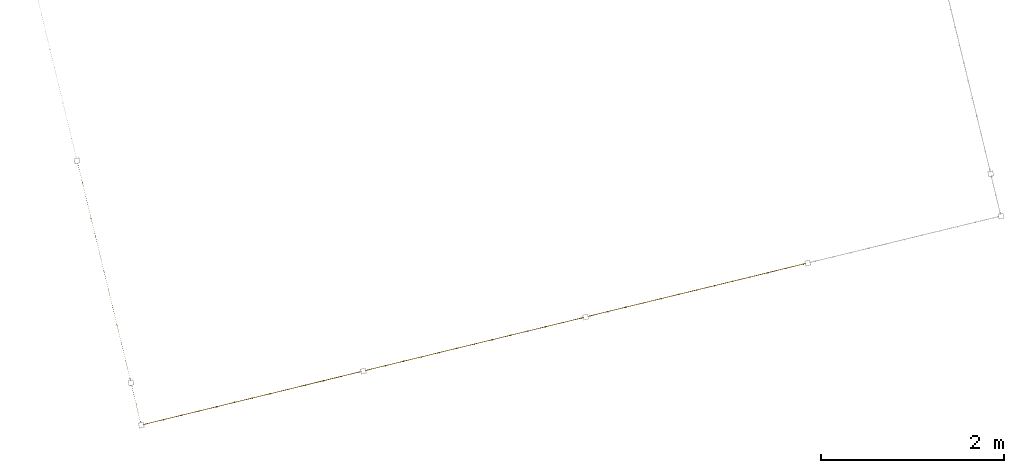
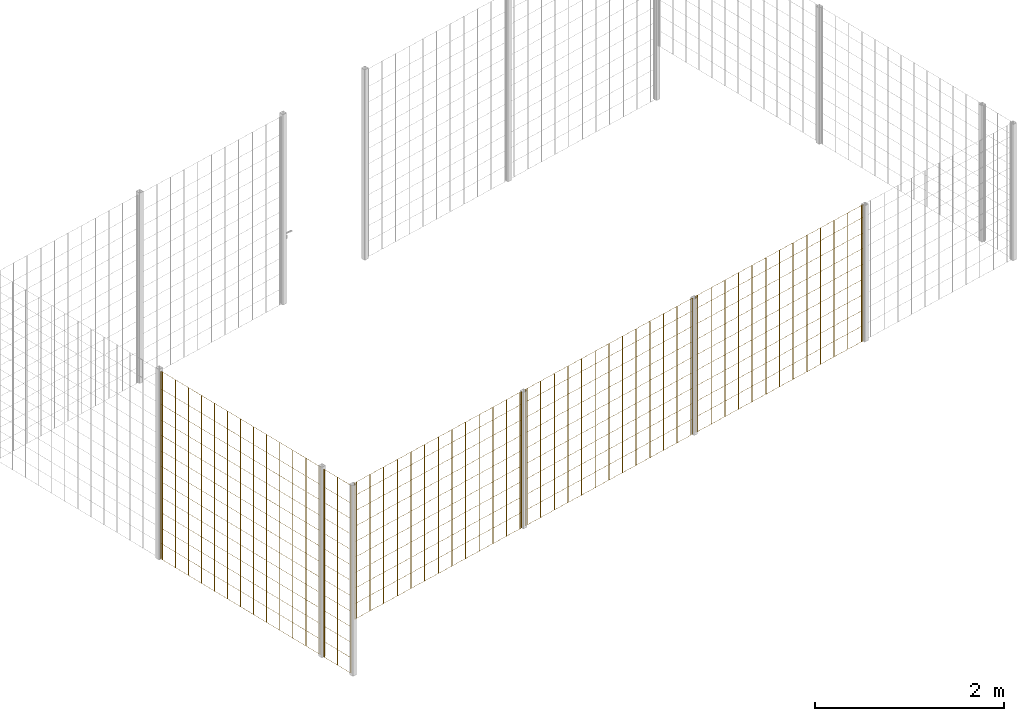
# One storey, part 7 of 10: 5 railings.
"""IFC2X3 building model written with IfcOpenShell, lengths in millimetres."""

import ifcopenshell
import ifcopenshell.guid

model = None  # the IFC model being written
_history = None  # IfcOwnerHistory: only IFC2X3 demands one
_inside = {}  # id of a spatial element -> (the spatial element, [elements in it])
_under = {}  # id of a project, library or spatial element -> (it, [spatial elements below it])
_declared = {}  # id of a project -> (the project, [libraries it declares])
_typed = {}  # id of a type object -> (the type object, [elements of that type])
_made_of = {}  # id of a material, layer set ... -> (it, [elements and type objects made of it])


def new_model(schema):
    """Start an empty IFC model of exactly this schema.

    Asked for "IFC4X3", IfcOpenShell would pick the latest addendum, in which some entities
    have other attributes; the version numbers below select the first issue.
    IFC2X3 requires an IfcOwnerHistory on every rooted entity: one is made here for all.
    """
    global model, _history
    if schema == "IFC4X3":
        model = ifcopenshell.file(schema_version=(4, 3, 0, 0))
    else:
        model = ifcopenshell.file(schema=schema)
    _inside.clear()
    _under.clear()
    _declared.clear()
    _typed.clear()
    _made_of.clear()
    _history = None
    if model.schema == "IFC2X3":
        org = make("IfcOrganization", Name="unknown")
        user = make(
            "IfcPersonAndOrganization",
            ThePerson=make("IfcPerson", FamilyName="unknown"),
            TheOrganization=org,
        )
        app = make(
            "IfcApplication",
            ApplicationDeveloper=org,
            Version="unknown",
            ApplicationFullName="unknown",
            ApplicationIdentifier="unknown",
        )
        _history = make(
            "IfcOwnerHistory",
            OwningUser=user,
            OwningApplication=app,
            ChangeAction="ADDED",
            CreationDate=0,
        )
    return model


def make(cls, **values):
    """One entity of the class cls with the attributes given. An attribute that is None is left unset."""
    return model.create_entity(
        cls, **{name: value for name, value in values.items() if value is not None}
    )


def entity(cls, *values):
    """Any entity or typed value of the class cls, its attributes in the order of the schema. None: left unset."""
    e = model.create_entity(cls)
    for i, value in enumerate(values):
        if value is not None:
            e[i] = value
    return e


def rooted(cls, **values):
    """An entity with a GlobalId (a new one), such as an element, a storey or a relation."""
    return make(cls, GlobalId=ifcopenshell.guid.new(), OwnerHistory=_history, **values)


def si_unit(unit_type, name, prefix=None):
    """IfcSIUnit, for example si_unit("LENGTHUNIT", "METRE", prefix="MILLI")."""
    return make("IfcSIUnit", UnitType=unit_type, Prefix=prefix, Name=name)


def converted_unit(unit_type, name, factor, base, dimensions=None, offset=None):
    """IfcConversionBasedUnit, such as the inch: factor (a typed value) times the base unit."""
    return make(
        "IfcConversionBasedUnit"
        if offset is None
        else "IfcConversionBasedUnitWithOffset",
        ConversionOffset=offset,
        Dimensions=None
        if dimensions is None
        else entity("IfcDimensionalExponents", *dimensions),
        UnitType=unit_type,
        Name=name,
        ConversionFactor=make(
            "IfcMeasureWithUnit", ValueComponent=factor, UnitComponent=base
        ),
    )


def derived_unit(unit_type, elements):
    """IfcDerivedUnit: a product of units, each with its exponent."""
    return make(
        "IfcDerivedUnit",
        Elements=[
            make("IfcDerivedUnitElement", Unit=unit, Exponent=power)
            for unit, power in elements
        ],
        UnitType=unit_type,
    )


def assignment(units):
    """IfcUnitAssignment: the units of a project."""
    return None if units is None else make("IfcUnitAssignment", Units=units)


def point(xyz):
    """IfcCartesianPoint."""
    return None if xyz is None else make("IfcCartesianPoint", Coordinates=xyz)


def direction(xyz):
    """IfcDirection."""
    return None if xyz is None else make("IfcDirection", DirectionRatios=xyz)


def frame(location, z_axis=None, x_axis=None):
    """IfcAxis2Placement3D, a coordinate frame: its origin and axes. An axis left out is left unset."""
    return make(
        "IfcAxis2Placement3D",
        Location=point(location),
        Axis=direction(z_axis),
        RefDirection=direction(x_axis),
    )


def frame_2d(location, x_axis=None):
    """IfcAxis2Placement2D, a coordinate frame in the plane: its origin and x axis."""
    return make(
        "IfcAxis2Placement2D", Location=point(location), RefDirection=direction(x_axis)
    )


def origin():
    """The frame at (0, 0, 0) with its axes left unset."""
    return frame((0.0, 0.0, 0.0))


def origin_2d_with_axis():
    """The frame at (0, 0) in the plane with the x axis (1, 0) written out."""
    return frame_2d((0.0, 0.0), x_axis=(1.0, 0.0))


def place(relative_to, where):
    """IfcLocalPlacement: puts the frame where relative to a parent placement (None: the world)."""
    return make(
        "IfcLocalPlacement", PlacementRelTo=relative_to, RelativePlacement=where
    )


def context(
    kind, dimensions, precision=None, world=None, true_north=None, identifier=None
):
    """IfcGeometricRepresentationContext, for example the 3D "Model" context."""
    return make(
        "IfcGeometricRepresentationContext",
        ContextIdentifier=identifier,
        ContextType=kind,
        CoordinateSpaceDimension=dimensions,
        Precision=precision,
        WorldCoordinateSystem=world,
        TrueNorth=true_north,
    )


def subcontext(parent, identifier, kind, view, scale=None):
    """IfcGeometricRepresentationSubContext, for example "Body" below "Model"."""
    return make(
        "IfcGeometricRepresentationSubContext",
        ContextIdentifier=identifier,
        ContextType=kind,
        ParentContext=parent,
        TargetScale=scale,
        TargetView=view,
    )


def project(units=None, contexts=None):
    """IfcProject with its units and contexts."""
    return rooted(
        "IfcProject",
        Name="project",
        RepresentationContexts=contexts,
        UnitsInContext=assignment(units),
    )


def spatial(cls, under=None, at=None, **own):
    """A site, building, storey or space (cls), placed at a placement, below another one or the project."""
    s = rooted(cls, ObjectPlacement=at, **own)
    if under is not None:
        _under.setdefault(under.id(), (under, []))[1].append(s)
    return s


def profile(cls, at=None, kind="AREA", **sizes):
    """A parametric profile (cls). Its sizes go by their IFC names, for example OverallWidth=200.0."""
    return make(cls, ProfileType=kind, Position=at, **sizes)


def rectangle(**sizes):
    """IfcRectangleProfileDef."""
    return profile("IfcRectangleProfileDef", **sizes)


def circle(**sizes):
    """IfcCircleProfileDef."""
    return profile("IfcCircleProfileDef", **sizes)


def extrude(swept, where, along, depth):
    """IfcExtrudedAreaSolid: the profile swept, set in the frame where, extruded along a direction by depth."""
    return make(
        "IfcExtrudedAreaSolid",
        SweptArea=swept,
        Position=where,
        ExtrudedDirection=direction(along),
        Depth=depth,
    )


def shape(context_of_items, identifier, shape_type, items):
    """IfcShapeRepresentation: the items that make up one representation, for example the "Body"."""
    return make(
        "IfcShapeRepresentation",
        ContextOfItems=context_of_items,
        RepresentationIdentifier=identifier,
        RepresentationType=shape_type,
        Items=items,
    )


def material(Name=None, Category=None):
    """IfcMaterial."""
    return make("IfcMaterial", Name=Name, Category=Category)


def material_list(materials):
    """IfcMaterialList."""
    return make("IfcMaterialList", Materials=materials)


def made_of(thing, what):
    """Note that an element or type object is made of a material, layer set ...; save() writes the relation."""
    if what is not None:
        _made_of.setdefault(what.id(), (what, []))[1].append(thing)
    return thing


def element(
    cls,
    number,
    at=None,
    inside=None,
    cuts=None,
    type_object=None,
    material=None,
    context=None,
    identifier="Body",
    shape_type=None,
    held_by="IfcProductDefinitionShape",
    body=None,
    shapes=None,
    **own,
):
    """One element of the class cls, such as IfcWall. Its Tag is "e" and its number.

    at: its placement. inside: the storey or other place that contains it. cuts: it is an
    opening in that element (IfcRelVoidsElement). A single representation is given by context,
    identifier, shape_type and body (its items); several are given by shapes. held_by: the class
    of the entity that holds the representations. save() writes the other relations.
    """
    e = rooted(cls, Tag="e%d" % number, ObjectPlacement=at, **own)
    if body is not None:
        shapes = [shape(context, identifier, shape_type, body)]
    if shapes is not None:
        e.Representation = make(held_by, Representations=shapes)
    if inside is not None:
        _inside.setdefault(inside.id(), (inside, []))[1].append(e)
    if cuts is not None:
        rooted(
            "IfcRelVoidsElement", RelatingBuildingElement=cuts, RelatedOpeningElement=e
        )
    if type_object is not None:
        _typed.setdefault(type_object.id(), (type_object, []))[1].append(e)
    return made_of(e, material)


def aggregate(whole, parts):
    """IfcRelAggregates: a whole, such as a stair, and the parts it consists of."""
    return rooted("IfcRelAggregates", RelatingObject=whole, RelatedObjects=parts)


def save(model, path):
    """Write the relations noted so far, then the file.

    IfcRelAggregates (storeys below a building ...), IfcRelContainedInSpatialStructure (elements
    in a storey), IfcRelDefinesByType, IfcRelAssociatesMaterial and IfcRelDeclares: one each for
    every whole, place, type object, material and project.
    """
    for whole, parts in _under.values():
        aggregate(whole, parts)
    for where, things in _inside.values():
        rooted(
            "IfcRelContainedInSpatialStructure",
            RelatedElements=things,
            RelatingStructure=where,
        )
    for kind, things in _typed.values():
        rooted("IfcRelDefinesByType", RelatedObjects=things, RelatingType=kind)
    for what, things in _made_of.values():
        rooted("IfcRelAssociatesMaterial", RelatedObjects=things, RelatingMaterial=what)
    for by, libraries in _declared.values():
        rooted("IfcRelDeclares", RelatingContext=by, RelatedDefinitions=libraries)
    model.write(path)


model = new_model("IFC2X3")

# Units and contexts
model_context = context("Model", 3, precision=0.01, world=origin(), true_north=direction((6.12303176911189e-17, 1.0)))
body_context = subcontext(model_context, "Body", "Model", "MODEL_VIEW")
ifc_project = project(units=[si_unit("LENGTHUNIT", "METRE", prefix="MILLI"), si_unit("AREAUNIT", "SQUARE_METRE"), si_unit("VOLUMEUNIT", "CUBIC_METRE"), converted_unit("PLANEANGLEUNIT", "DEGREE", entity("IfcRatioMeasure", 0.0174532925199433), si_unit("PLANEANGLEUNIT", "RADIAN"), dimensions=[0, 0, 0, 0, 0, 0, 0]), si_unit("MASSUNIT", "GRAM", prefix="KILO"), derived_unit("MASSDENSITYUNIT", [(si_unit("MASSUNIT", "GRAM", prefix="KILO"), 1), (si_unit("LENGTHUNIT", "METRE"), -3)]), derived_unit("MOMENTOFINERTIAUNIT", [(si_unit("LENGTHUNIT", "METRE"), 4)]), si_unit("TIMEUNIT", "SECOND"), si_unit("FREQUENCYUNIT", "HERTZ"), si_unit("THERMODYNAMICTEMPERATUREUNIT", "DEGREE_CELSIUS"), derived_unit("THERMALTRANSMITTANCEUNIT", [(si_unit("MASSUNIT", "GRAM", prefix="KILO"), 1), (si_unit("THERMODYNAMICTEMPERATUREUNIT", "KELVIN"), -1), (si_unit("TIMEUNIT", "SECOND"), -3)]), derived_unit("VOLUMETRICFLOWRATEUNIT", [(si_unit("LENGTHUNIT", "METRE"), 3), (si_unit("TIMEUNIT", "SECOND"), -1)]), derived_unit("MASSFLOWRATEUNIT", [(si_unit("MASSUNIT", "GRAM", prefix="KILO"), 1), (si_unit("TIMEUNIT", "SECOND"), -1)]), derived_unit("ROTATIONALFREQUENCYUNIT", [(si_unit("TIMEUNIT", "SECOND"), -1)]), si_unit("ELECTRICCURRENTUNIT", "AMPERE"), si_unit("ELECTRICVOLTAGEUNIT", "VOLT"), si_unit("POWERUNIT", "WATT"), si_unit("FORCEUNIT", "NEWTON", prefix="KILO"), si_unit("ILLUMINANCEUNIT", "LUX"), si_unit("LUMINOUSFLUXUNIT", "LUMEN"), si_unit("LUMINOUSINTENSITYUNIT", "CANDELA"), derived_unit("USERDEFINED", [(si_unit("MASSUNIT", "GRAM", prefix="KILO"), -1), (si_unit("LENGTHUNIT", "METRE"), -2), (si_unit("TIMEUNIT", "SECOND"), 3), (si_unit("LUMINOUSFLUXUNIT", "LUMEN"), 1)]), derived_unit("LINEARVELOCITYUNIT", [(si_unit("LENGTHUNIT", "METRE"), 1), (si_unit("TIMEUNIT", "SECOND"), -1)]), si_unit("PRESSUREUNIT", "PASCAL"), derived_unit("USERDEFINED", [(si_unit("LENGTHUNIT", "METRE"), -2), (si_unit("MASSUNIT", "GRAM", prefix="KILO"), 1), (si_unit("TIMEUNIT", "SECOND"), -2)]), derived_unit("LINEARFORCEUNIT", [(si_unit("MASSUNIT", "GRAM", prefix="KILO"), 1), (si_unit("LENGTHUNIT", "METRE"), 1), (si_unit("TIMEUNIT", "SECOND"), -2), (si_unit("LENGTHUNIT", "METRE"), -1)]), derived_unit("PLANARFORCEUNIT", [(si_unit("MASSUNIT", "GRAM", prefix="KILO"), 1), (si_unit("LENGTHUNIT", "METRE"), 1), (si_unit("TIMEUNIT", "SECOND"), -2), (si_unit("LENGTHUNIT", "METRE"), -2)])], contexts=[model_context])

# Site, building, storey
site_placement = place(None, frame((19171.746869958, -72498.5768491146, 0.0), z_axis=(0.0, 0.0, 1.0), x_axis=(0.971695960795463, 0.236234967296933, 0.0)))
site = spatial("IfcSite", under=ifc_project, at=site_placement, CompositionType="ELEMENT")
building_placement = place(site_placement, origin())
building = spatial("IfcBuilding", under=site, at=building_placement, CompositionType="ELEMENT")
storey_placement = place(building_placement, origin())
storey = spatial("IfcBuildingStorey", under=building, at=storey_placement, CompositionType="ELEMENT", Elevation=0.0)

# Railings
ifc_material = material()
ifc_material_list_1 = material_list([ifc_material, ifc_material, ifc_material, ifc_material, ifc_material, ifc_material, ifc_material, ifc_material, ifc_material, ifc_material, ifc_material, ifc_material, ifc_material, ifc_material, ifc_material, ifc_material, ifc_material, ifc_material, ifc_material, ifc_material, ifc_material, ifc_material, ifc_material, ifc_material, ifc_material, ifc_material, ifc_material, ifc_material])
railing_1_placement = place(storey_placement, frame((193.41250000003, 620.912499999968, 0.0)))
element("IfcRailing", 1, at=railing_1_placement, inside=storey, material=ifc_material_list_1, PredefinedType="NOTDEFINED", context=body_context, shape_type="SweptSolid", body=[
    extrude(circle(Radius=5.0, at=origin_2d_with_axis()), frame((6.58750000000395, 2429.0875, 2.0), z_axis=(0.0, 0.0, 1.0), x_axis=(-1.0, 0.0, 0.0)), (0.0, 0.0, 1.0), 2428.0),
    extrude(circle(Radius=5.0, at=origin_2d_with_axis()), frame((6.58750000000361, 2229.0875, 2.0), z_axis=(0.0, 0.0, 1.0), x_axis=(-1.0, 0.0, 0.0)), (0.0, 0.0, 1.0), 2428.0),
    extrude(circle(Radius=5.0, at=origin_2d_with_axis()), frame((6.58750000000331, 2029.0875, 2.0), z_axis=(0.0, 0.0, 1.0), x_axis=(-1.0, 0.0, 0.0)), (0.0, 0.0, 1.0), 2428.0),
    extrude(circle(Radius=5.0, at=origin_2d_with_axis()), frame((6.58750000000297, 1829.0875, 2.0), z_axis=(0.0, 0.0, 1.0), x_axis=(-1.0, 0.0, 0.0)), (0.0, 0.0, 1.0), 2428.0),
    extrude(circle(Radius=5.0, at=origin_2d_with_axis()), frame((6.58750000000266, 1629.0875, 2.0), z_axis=(0.0, 0.0, 1.0), x_axis=(-1.0, 0.0, 0.0)), (0.0, 0.0, 1.0), 2428.0),
    extrude(circle(Radius=5.0, at=origin_2d_with_axis()), frame((6.58750000000233, 1429.0875, 2.0), z_axis=(0.0, 0.0, 1.0), x_axis=(-1.0, 0.0, 0.0)), (0.0, 0.0, 1.0), 2428.0),
    extrude(circle(Radius=5.0, at=origin_2d_with_axis()), frame((6.58750000000199, 1229.0875, 2.0), z_axis=(0.0, 0.0, 1.0), x_axis=(-1.0, 0.0, 0.0)), (0.0, 0.0, 1.0), 2428.0),
    extrude(circle(Radius=5.0, at=origin_2d_with_axis()), frame((6.58750000000168, 1029.0875, 2.0), z_axis=(0.0, 0.0, 1.0), x_axis=(-1.0, 0.0, 0.0)), (0.0, 0.0, 1.0), 2428.0),
    extrude(circle(Radius=5.0, at=origin_2d_with_axis()), frame((6.58750000000135, 829.087500000001, 2.0), z_axis=(0.0, 0.0, 1.0), x_axis=(-1.0, 0.0, 0.0)), (0.0, 0.0, 1.0), 2428.0),
    extrude(circle(Radius=5.0, at=origin_2d_with_axis()), frame((6.58750000000104, 629.087500000001, 2.0), z_axis=(0.0, 0.0, 1.0), x_axis=(-1.0, 0.0, 0.0)), (0.0, 0.0, 1.0), 2428.0),
    extrude(circle(Radius=5.0, at=origin_2d_with_axis()), frame((6.5875000000007, 429.087500000001, 2.0), z_axis=(0.0, 0.0, 1.0), x_axis=(-1.0, 0.0, 0.0)), (0.0, 0.0, 1.0), 2428.0),
    extrude(circle(Radius=5.0, at=origin_2d_with_axis()), frame((6.5875000000004, 229.087500000001, 2.0), z_axis=(0.0, 0.0, 1.0), x_axis=(-1.0, 0.0, 0.0)), (0.0, 0.0, 1.0), 2428.0),
    extrude(circle(Radius=5.0, at=origin_2d_with_axis()), frame((6.58750000000006, 29.0875000000008, 2.0), z_axis=(0.0, 0.0, 1.0), x_axis=(-1.0, 0.0, 0.0)), (0.0, 0.0, 1.0), 2428.0),
    extrude(circle(Radius=5.0, at=origin_2d_with_axis()), frame((6.58750000000398, 2451.5875, 2.0), z_axis=(0.0, 0.0, 1.0), x_axis=(-1.0, 0.0, 0.0)), (0.0, 0.0, 1.0), 2428.0),
    extrude(circle(Radius=5.0, at=origin_2d_with_axis()), frame((6.58750000000003, 6.58749999999999, 2.0), z_axis=(0.0, 0.0, 1.0), x_axis=(-1.0, 0.0, 0.0)), (0.0, 0.0, 1.0), 2428.0),
    extrude(rectangle(XDim=2445.0, YDim=1.99999999999988, at=frame_2d((-1.13686837721616e-13, 1.69309011255336e-14), x_axis=(1.0, 0.0))), frame((7.58750000000196, 1229.0875, 0.0), z_axis=(0.0, 0.0, 1.0), x_axis=(0.0, 1.0, 0.0)), (0.0, 0.0, 1.0), 2.00000000000043),
    extrude(rectangle(XDim=2445.0, YDim=1.99999999999988, at=frame_2d((-1.13686837721616e-13, 1.69309011255336e-14), x_axis=(1.0, 0.0))), frame((7.58750000000196, 1229.0875, 200.0), z_axis=(0.0, 0.0, 1.0), x_axis=(0.0, 1.0, 0.0)), (0.0, 0.0, 1.0), 2.00000000000043),
    extrude(rectangle(XDim=2445.0, YDim=1.99999999999988, at=frame_2d((-1.13686837721616e-13, 1.69309011255336e-14), x_axis=(1.0, 0.0))), frame((7.58750000000196, 1229.0875, 400.0), z_axis=(0.0, 0.0, 1.0), x_axis=(0.0, 1.0, 0.0)), (0.0, 0.0, 1.0), 2.00000000000043),
    extrude(rectangle(XDim=2445.0, YDim=1.99999999999988, at=frame_2d((-1.13686837721616e-13, 1.69309011255336e-14), x_axis=(1.0, 0.0))), frame((7.58750000000196, 1229.0875, 600.0), z_axis=(0.0, 0.0, 1.0), x_axis=(0.0, 1.0, 0.0)), (0.0, 0.0, 1.0), 2.00000000000043),
    extrude(rectangle(XDim=2445.0, YDim=1.99999999999988, at=frame_2d((-1.13686837721616e-13, 1.69309011255336e-14), x_axis=(1.0, 0.0))), frame((7.58750000000196, 1229.0875, 800.0), z_axis=(0.0, 0.0, 1.0), x_axis=(0.0, 1.0, 0.0)), (0.0, 0.0, 1.0), 2.00000000000036),
    extrude(rectangle(XDim=2445.0, YDim=1.99999999999988, at=frame_2d((-1.13686837721616e-13, 1.69309011255336e-14), x_axis=(1.0, 0.0))), frame((7.58750000000196, 1229.0875, 1000.0), z_axis=(0.0, 0.0, 1.0), x_axis=(0.0, 1.0, 0.0)), (0.0, 0.0, 1.0), 2.00000000000036),
    extrude(rectangle(XDim=2445.0, YDim=1.99999999999988, at=frame_2d((-1.13686837721616e-13, 1.69309011255336e-14), x_axis=(1.0, 0.0))), frame((7.58750000000196, 1229.0875, 1200.0), z_axis=(0.0, 0.0, 1.0), x_axis=(0.0, 1.0, 0.0)), (0.0, 0.0, 1.0), 2.00000000000036),
    extrude(rectangle(XDim=2445.0, YDim=1.99999999999988, at=frame_2d((-1.13686837721616e-13, 1.69309011255336e-14), x_axis=(1.0, 0.0))), frame((7.58750000000196, 1229.0875, 1400.0), z_axis=(0.0, 0.0, 1.0), x_axis=(0.0, 1.0, 0.0)), (0.0, 0.0, 1.0), 2.00000000000036),
    extrude(rectangle(XDim=2445.0, YDim=1.99999999999988, at=frame_2d((-1.13686837721616e-13, 1.69309011255336e-14), x_axis=(1.0, 0.0))), frame((7.58750000000196, 1229.0875, 1600.0), z_axis=(0.0, 0.0, 1.0), x_axis=(0.0, 1.0, 0.0)), (0.0, 0.0, 1.0), 2.00000000000036),
    extrude(rectangle(XDim=2445.0, YDim=1.99999999999988, at=frame_2d((-1.13686837721616e-13, 1.69309011255336e-14), x_axis=(1.0, 0.0))), frame((7.58750000000196, 1229.0875, 1800.0), z_axis=(0.0, 0.0, 1.0), x_axis=(0.0, 1.0, 0.0)), (0.0, 0.0, 1.0), 2.00000000000036),
    extrude(rectangle(XDim=2445.0, YDim=1.99999999999988, at=frame_2d((-1.13686837721616e-13, 1.69309011255336e-14), x_axis=(1.0, 0.0))), frame((7.58750000000196, 1229.0875, 2000.0), z_axis=(0.0, 0.0, 1.0), x_axis=(0.0, 1.0, 0.0)), (0.0, 0.0, 1.0), 2.00000000000036),
    extrude(rectangle(XDim=2445.0, YDim=1.99999999999988, at=frame_2d((-1.13686837721616e-13, 1.69309011255336e-14), x_axis=(1.0, 0.0))), frame((7.58750000000196, 1229.0875, 2200.0), z_axis=(0.0, 0.0, 1.0), x_axis=(0.0, 1.0, 0.0)), (0.0, 0.0, 1.0), 2.00000000000036),
    extrude(rectangle(XDim=2445.0, YDim=1.99999999999988, at=frame_2d((-1.13686837721616e-13, 1.69309011255336e-14), x_axis=(1.0, 0.0))), frame((7.58750000000196, 1229.0875, 2430.0), z_axis=(0.0, 0.0, 1.0), x_axis=(0.0, 1.0, 0.0)), (0.0, 0.0, 1.0), 2.00000000000036),
])
ifc_material_list_2 = material_list([ifc_material, ifc_material, ifc_material, ifc_material, ifc_material, ifc_material, ifc_material, ifc_material, ifc_material, ifc_material, ifc_material, ifc_material, ifc_material, ifc_material, ifc_material, ifc_material, ifc_material, ifc_material, ifc_material, ifc_material, ifc_material, ifc_material, ifc_material, ifc_material, ifc_material])
railing_2_placement = place(storey_placement, frame((5220.91250000003, 118.412499999968, 700.0)))
element("IfcRailing", 2, at=railing_2_placement, inside=storey, material=ifc_material_list_2, PredefinedType="NOTDEFINED", context=body_context, shape_type="SweptSolid", body=[
    extrude(circle(Radius=5.0, at=origin_2d_with_axis()), frame((29.7874999999986, 6.58750000000783, 2.0), z_axis=(0.0, 0.0, 1.0), x_axis=(0.0, -1.0, 0.0)), (0.0, 0.0, 1.0), 1763.0),
    extrude(circle(Radius=5.0, at=origin_2d_with_axis()), frame((229.787499999999, 6.58750000000718, 2.0), z_axis=(0.0, 0.0, 1.0), x_axis=(0.0, -1.0, 0.0)), (0.0, 0.0, 1.0), 1763.0),
    extrude(circle(Radius=5.0, at=origin_2d_with_axis()), frame((429.787499999999, 6.58750000000654, 2.0), z_axis=(0.0, 0.0, 1.0), x_axis=(0.0, -1.0, 0.0)), (0.0, 0.0, 1.0), 1763.0),
    extrude(circle(Radius=5.0, at=origin_2d_with_axis()), frame((629.787499999999, 6.5875000000059, 2.0), z_axis=(0.0, 0.0, 1.0), x_axis=(0.0, -1.0, 0.0)), (0.0, 0.0, 1.0), 1763.0),
    extrude(circle(Radius=5.0, at=origin_2d_with_axis()), frame((829.787499999999, 6.58750000000524, 2.0), z_axis=(0.0, 0.0, 1.0), x_axis=(0.0, -1.0, 0.0)), (0.0, 0.0, 1.0), 1763.0),
    extrude(circle(Radius=5.0, at=origin_2d_with_axis()), frame((1029.7875, 6.58750000000459, 2.0), z_axis=(0.0, 0.0, 1.0), x_axis=(0.0, -1.0, 0.0)), (0.0, 0.0, 1.0), 1763.0),
    extrude(circle(Radius=5.0, at=origin_2d_with_axis()), frame((1229.7875, 6.58750000000395, 2.0), z_axis=(0.0, 0.0, 1.0), x_axis=(0.0, -1.0, 0.0)), (0.0, 0.0, 1.0), 1763.0),
    extrude(circle(Radius=5.0, at=origin_2d_with_axis()), frame((1429.7875, 6.58750000000331, 2.0), z_axis=(0.0, 0.0, 1.0), x_axis=(0.0, -1.0, 0.0)), (0.0, 0.0, 1.0), 1763.0),
    extrude(circle(Radius=5.0, at=origin_2d_with_axis()), frame((1629.7875, 6.58750000000265, 2.0), z_axis=(0.0, 0.0, 1.0), x_axis=(0.0, -1.0, 0.0)), (0.0, 0.0, 1.0), 1763.0),
    extrude(circle(Radius=5.0, at=origin_2d_with_axis()), frame((1829.7875, 6.58750000000201, 2.0), z_axis=(0.0, 0.0, 1.0), x_axis=(0.0, -1.0, 0.0)), (0.0, 0.0, 1.0), 1763.0),
    extrude(circle(Radius=5.0, at=origin_2d_with_axis()), frame((2029.7875, 6.58750000000136, 2.0), z_axis=(0.0, 0.0, 1.0), x_axis=(0.0, -1.0, 0.0)), (0.0, 0.0, 1.0), 1763.0),
    extrude(circle(Radius=5.0, at=origin_2d_with_axis()), frame((2229.7875, 6.58750000000072, 2.0), z_axis=(0.0, 0.0, 1.0), x_axis=(0.0, -1.0, 0.0)), (0.0, 0.0, 1.0), 1763.0),
    extrude(circle(Radius=5.0, at=origin_2d_with_axis()), frame((2429.7875, 6.58750000000006, 2.0), z_axis=(0.0, 0.0, 1.0), x_axis=(0.0, -1.0, 0.0)), (0.0, 0.0, 1.0), 1763.0),
    extrude(circle(Radius=5.0, at=origin_2d_with_axis()), frame((6.58749999999959, 6.58750000000791, 2.0), z_axis=(0.0, 0.0, 1.0), x_axis=(0.0, -1.0, 0.0)), (0.0, 0.0, 1.0), 1763.0),
    extrude(circle(Radius=5.0, at=origin_2d_with_axis()), frame((2452.9875, 6.58749999999999, 2.0), z_axis=(0.0, 0.0, 1.0), x_axis=(0.0, -1.0, 0.0)), (0.0, 0.0, 1.0), 1763.0),
    extrude(rectangle(XDim=2446.4, YDim=1.99999999999988, at=frame_2d((-5.6843418860808e-13, 0.0), x_axis=(1.0, 0.0))), frame((1229.7875, 7.58750000000389, 0.0), z_axis=(0.0, 0.0, 1.0), x_axis=(-1.0, 0.0, 0.0)), (0.0, 0.0, 1.0), 2.00000000000036),
    extrude(rectangle(XDim=2446.4, YDim=1.99999999999988, at=frame_2d((-5.6843418860808e-13, 0.0), x_axis=(1.0, 0.0))), frame((1229.7875, 7.58750000000389, 200.0), z_axis=(0.0, 0.0, 1.0), x_axis=(-1.0, 0.0, 0.0)), (0.0, 0.0, 1.0), 2.00000000000036),
    extrude(rectangle(XDim=2446.4, YDim=1.99999999999988, at=frame_2d((-5.6843418860808e-13, 0.0), x_axis=(1.0, 0.0))), frame((1229.7875, 7.58750000000389, 400.0), z_axis=(0.0, 0.0, 1.0), x_axis=(-1.0, 0.0, 0.0)), (0.0, 0.0, 1.0), 2.00000000000036),
    extrude(rectangle(XDim=2446.4, YDim=1.99999999999988, at=frame_2d((-5.6843418860808e-13, 0.0), x_axis=(1.0, 0.0))), frame((1229.7875, 7.58750000000389, 600.0), z_axis=(0.0, 0.0, 1.0), x_axis=(-1.0, 0.0, 0.0)), (0.0, 0.0, 1.0), 2.00000000000036),
    extrude(rectangle(XDim=2446.4, YDim=1.99999999999988, at=frame_2d((-5.6843418860808e-13, 0.0), x_axis=(1.0, 0.0))), frame((1229.7875, 7.58750000000389, 800.0), z_axis=(0.0, 0.0, 1.0), x_axis=(-1.0, 0.0, 0.0)), (0.0, 0.0, 1.0), 2.00000000000036),
    extrude(rectangle(XDim=2446.4, YDim=1.99999999999988, at=frame_2d((-5.6843418860808e-13, 0.0), x_axis=(1.0, 0.0))), frame((1229.7875, 7.58750000000389, 1000.0), z_axis=(0.0, 0.0, 1.0), x_axis=(-1.0, 0.0, 0.0)), (0.0, 0.0, 1.0), 2.00000000000036),
    extrude(rectangle(XDim=2446.4, YDim=1.99999999999988, at=frame_2d((-5.6843418860808e-13, 0.0), x_axis=(1.0, 0.0))), frame((1229.7875, 7.58750000000389, 1200.0), z_axis=(0.0, 0.0, 1.0), x_axis=(-1.0, 0.0, 0.0)), (0.0, 0.0, 1.0), 2.00000000000036),
    extrude(rectangle(XDim=2446.4, YDim=1.99999999999988, at=frame_2d((-5.6843418860808e-13, 0.0), x_axis=(1.0, 0.0))), frame((1229.7875, 7.58750000000389, 1400.0), z_axis=(0.0, 0.0, 1.0), x_axis=(-1.0, 0.0, 0.0)), (0.0, 0.0, 1.0), 2.00000000000036),
    extrude(rectangle(XDim=2446.4, YDim=1.99999999999988, at=frame_2d((-5.6843418860808e-13, 0.0), x_axis=(1.0, 0.0))), frame((1229.7875, 7.58750000000389, 1600.0), z_axis=(0.0, 0.0, 1.0), x_axis=(-1.0, 0.0, 0.0)), (0.0, 0.0, 1.0), 2.00000000000036),
    extrude(rectangle(XDim=2446.4, YDim=1.99999999999988, at=frame_2d((-5.6843418860808e-13, 0.0), x_axis=(1.0, 0.0))), frame((1229.7875, 7.58750000000389, 1765.0), z_axis=(0.0, 0.0, 1.0), x_axis=(-1.0, 0.0, 0.0)), (0.0, 0.0, 1.0), 2.00000000000063),
])
ifc_material_list_3 = material_list([ifc_material, ifc_material, ifc_material, ifc_material, ifc_material, ifc_material, ifc_material, ifc_material, ifc_material, ifc_material, ifc_material, ifc_material, ifc_material, ifc_material, ifc_material, ifc_material, ifc_material, ifc_material, ifc_material, ifc_material, ifc_material, ifc_material, ifc_material, ifc_material, ifc_material])
railing_3_placement = place(storey_placement, frame((2720.91250000003, 118.412499999968, 700.0)))
element("IfcRailing", 3, at=railing_3_placement, inside=storey, material=ifc_material_list_3, PredefinedType="NOTDEFINED", context=body_context, shape_type="SweptSolid", body=[
    extrude(circle(Radius=5.0, at=origin_2d_with_axis()), frame((29.0874999999999, 6.58750000000783, 2.0), z_axis=(0.0, 0.0, 1.0), x_axis=(0.0, -1.0, 0.0)), (0.0, 0.0, 1.0), 1763.0),
    extrude(circle(Radius=5.0, at=origin_2d_with_axis()), frame((229.0875, 6.58750000000718, 2.0), z_axis=(0.0, 0.0, 1.0), x_axis=(0.0, -1.0, 0.0)), (0.0, 0.0, 1.0), 1763.0),
    extrude(circle(Radius=5.0, at=origin_2d_with_axis()), frame((429.0875, 6.58750000000652, 2.0), z_axis=(0.0, 0.0, 1.0), x_axis=(0.0, -1.0, 0.0)), (0.0, 0.0, 1.0), 1763.0),
    extrude(circle(Radius=5.0, at=origin_2d_with_axis()), frame((629.0875, 6.58750000000588, 2.0), z_axis=(0.0, 0.0, 1.0), x_axis=(0.0, -1.0, 0.0)), (0.0, 0.0, 1.0), 1763.0),
    extrude(circle(Radius=5.0, at=origin_2d_with_axis()), frame((829.0875, 6.58750000000524, 2.0), z_axis=(0.0, 0.0, 1.0), x_axis=(0.0, -1.0, 0.0)), (0.0, 0.0, 1.0), 1763.0),
    extrude(circle(Radius=5.0, at=origin_2d_with_axis()), frame((1029.0875, 6.58750000000459, 2.0), z_axis=(0.0, 0.0, 1.0), x_axis=(0.0, -1.0, 0.0)), (0.0, 0.0, 1.0), 1763.0),
    extrude(circle(Radius=5.0, at=origin_2d_with_axis()), frame((1229.0875, 6.58750000000395, 2.0), z_axis=(0.0, 0.0, 1.0), x_axis=(0.0, -1.0, 0.0)), (0.0, 0.0, 1.0), 1763.0),
    extrude(circle(Radius=5.0, at=origin_2d_with_axis()), frame((1429.0875, 6.58750000000329, 2.0), z_axis=(0.0, 0.0, 1.0), x_axis=(0.0, -1.0, 0.0)), (0.0, 0.0, 1.0), 1763.0),
    extrude(circle(Radius=5.0, at=origin_2d_with_axis()), frame((1629.0875, 6.58750000000265, 2.0), z_axis=(0.0, 0.0, 1.0), x_axis=(0.0, -1.0, 0.0)), (0.0, 0.0, 1.0), 1763.0),
    extrude(circle(Radius=5.0, at=origin_2d_with_axis()), frame((1829.0875, 6.58750000000201, 2.0), z_axis=(0.0, 0.0, 1.0), x_axis=(0.0, -1.0, 0.0)), (0.0, 0.0, 1.0), 1763.0),
    extrude(circle(Radius=5.0, at=origin_2d_with_axis()), frame((2029.0875, 6.58750000000136, 2.0), z_axis=(0.0, 0.0, 1.0), x_axis=(0.0, -1.0, 0.0)), (0.0, 0.0, 1.0), 1763.0),
    extrude(circle(Radius=5.0, at=origin_2d_with_axis()), frame((2229.0875, 6.5875000000007, 2.0), z_axis=(0.0, 0.0, 1.0), x_axis=(0.0, -1.0, 0.0)), (0.0, 0.0, 1.0), 1763.0),
    extrude(circle(Radius=5.0, at=origin_2d_with_axis()), frame((2429.0875, 6.58750000000006, 2.0), z_axis=(0.0, 0.0, 1.0), x_axis=(0.0, -1.0, 0.0)), (0.0, 0.0, 1.0), 1763.0),
    extrude(circle(Radius=5.0, at=origin_2d_with_axis()), frame((6.58750000000013, 6.58750000000789, 2.0), z_axis=(0.0, 0.0, 1.0), x_axis=(0.0, -1.0, 0.0)), (0.0, 0.0, 1.0), 1763.0),
    extrude(circle(Radius=5.0, at=origin_2d_with_axis()), frame((2451.5875, 6.58749999999999, 2.0), z_axis=(0.0, 0.0, 1.0), x_axis=(0.0, -1.0, 0.0)), (0.0, 0.0, 1.0), 1763.0),
    extrude(rectangle(XDim=2445.0, YDim=1.9999999999999, at=frame_2d((-3.41060513164848e-13, 0.0), x_axis=(1.0, 0.0))), frame((1229.0875, 7.58750000000389, 0.0), z_axis=(0.0, 0.0, 1.0), x_axis=(-1.0, 0.0, 0.0)), (0.0, 0.0, 1.0), 2.00000000000036),
    extrude(rectangle(XDim=2445.0, YDim=1.9999999999999, at=frame_2d((-3.41060513164848e-13, 0.0), x_axis=(1.0, 0.0))), frame((1229.0875, 7.58750000000389, 200.0), z_axis=(0.0, 0.0, 1.0), x_axis=(-1.0, 0.0, 0.0)), (0.0, 0.0, 1.0), 2.00000000000036),
    extrude(rectangle(XDim=2445.0, YDim=1.9999999999999, at=frame_2d((-3.41060513164848e-13, 0.0), x_axis=(1.0, 0.0))), frame((1229.0875, 7.58750000000389, 400.0), z_axis=(0.0, 0.0, 1.0), x_axis=(-1.0, 0.0, 0.0)), (0.0, 0.0, 1.0), 2.00000000000036),
    extrude(rectangle(XDim=2445.0, YDim=1.9999999999999, at=frame_2d((-3.41060513164848e-13, 0.0), x_axis=(1.0, 0.0))), frame((1229.0875, 7.58750000000389, 600.0), z_axis=(0.0, 0.0, 1.0), x_axis=(-1.0, 0.0, 0.0)), (0.0, 0.0, 1.0), 2.00000000000036),
    extrude(rectangle(XDim=2445.0, YDim=1.9999999999999, at=frame_2d((-3.41060513164848e-13, 0.0), x_axis=(1.0, 0.0))), frame((1229.0875, 7.58750000000389, 800.0), z_axis=(0.0, 0.0, 1.0), x_axis=(-1.0, 0.0, 0.0)), (0.0, 0.0, 1.0), 2.00000000000036),
    extrude(rectangle(XDim=2445.0, YDim=1.9999999999999, at=frame_2d((-3.41060513164848e-13, 0.0), x_axis=(1.0, 0.0))), frame((1229.0875, 7.58750000000389, 1000.0), z_axis=(0.0, 0.0, 1.0), x_axis=(-1.0, 0.0, 0.0)), (0.0, 0.0, 1.0), 2.00000000000036),
    extrude(rectangle(XDim=2445.0, YDim=1.9999999999999, at=frame_2d((-3.41060513164848e-13, 0.0), x_axis=(1.0, 0.0))), frame((1229.0875, 7.58750000000389, 1200.0), z_axis=(0.0, 0.0, 1.0), x_axis=(-1.0, 0.0, 0.0)), (0.0, 0.0, 1.0), 2.00000000000036),
    extrude(rectangle(XDim=2445.0, YDim=1.9999999999999, at=frame_2d((-3.41060513164848e-13, 0.0), x_axis=(1.0, 0.0))), frame((1229.0875, 7.58750000000389, 1400.0), z_axis=(0.0, 0.0, 1.0), x_axis=(-1.0, 0.0, 0.0)), (0.0, 0.0, 1.0), 2.00000000000036),
    extrude(rectangle(XDim=2445.0, YDim=1.9999999999999, at=frame_2d((-3.41060513164848e-13, 0.0), x_axis=(1.0, 0.0))), frame((1229.0875, 7.58750000000389, 1600.0), z_axis=(0.0, 0.0, 1.0), x_axis=(-1.0, 0.0, 0.0)), (0.0, 0.0, 1.0), 2.00000000000036),
    extrude(rectangle(XDim=2445.0, YDim=1.9999999999999, at=frame_2d((-3.41060513164848e-13, 0.0), x_axis=(1.0, 0.0))), frame((1229.0875, 7.58750000000389, 1765.0), z_axis=(0.0, 0.0, 1.0), x_axis=(-1.0, 0.0, 0.0)), (0.0, 0.0, 1.0), 2.00000000000063),
])
ifc_material_list_4 = material_list([ifc_material, ifc_material, ifc_material, ifc_material, ifc_material, ifc_material, ifc_material, ifc_material, ifc_material, ifc_material, ifc_material, ifc_material, ifc_material, ifc_material, ifc_material, ifc_material, ifc_material, ifc_material, ifc_material, ifc_material, ifc_material, ifc_material, ifc_material, ifc_material, ifc_material])
railing_4_placement = place(storey_placement, frame((220.912500000033, 118.412499999969, 700.0)))
element("IfcRailing", 4, at=railing_4_placement, inside=storey, material=ifc_material_list_4, PredefinedType="NOTDEFINED", context=body_context, shape_type="SweptSolid", body=[
    extrude(circle(Radius=5.0, at=origin_2d_with_axis()), frame((29.0875000000001, 6.58750000000783, 2.0), z_axis=(0.0, 0.0, 1.0), x_axis=(0.0, -1.0, 0.0)), (0.0, 0.0, 1.0), 1763.0),
    extrude(circle(Radius=5.0, at=origin_2d_with_axis()), frame((229.0875, 6.58750000000718, 2.0), z_axis=(0.0, 0.0, 1.0), x_axis=(0.0, -1.0, 0.0)), (0.0, 0.0, 1.0), 1763.0),
    extrude(circle(Radius=5.0, at=origin_2d_with_axis()), frame((429.0875, 6.58750000000652, 2.0), z_axis=(0.0, 0.0, 1.0), x_axis=(0.0, -1.0, 0.0)), (0.0, 0.0, 1.0), 1763.0),
    extrude(circle(Radius=5.0, at=origin_2d_with_axis()), frame((629.0875, 6.58750000000588, 2.0), z_axis=(0.0, 0.0, 1.0), x_axis=(0.0, -1.0, 0.0)), (0.0, 0.0, 1.0), 1763.0),
    extrude(circle(Radius=5.0, at=origin_2d_with_axis()), frame((829.0875, 6.58750000000524, 2.0), z_axis=(0.0, 0.0, 1.0), x_axis=(0.0, -1.0, 0.0)), (0.0, 0.0, 1.0), 1763.0),
    extrude(circle(Radius=5.0, at=origin_2d_with_axis()), frame((1029.0875, 6.58750000000459, 2.0), z_axis=(0.0, 0.0, 1.0), x_axis=(0.0, -1.0, 0.0)), (0.0, 0.0, 1.0), 1763.0),
    extrude(circle(Radius=5.0, at=origin_2d_with_axis()), frame((1229.0875, 6.58750000000395, 2.0), z_axis=(0.0, 0.0, 1.0), x_axis=(0.0, -1.0, 0.0)), (0.0, 0.0, 1.0), 1763.0),
    extrude(circle(Radius=5.0, at=origin_2d_with_axis()), frame((1429.0875, 6.58750000000329, 2.0), z_axis=(0.0, 0.0, 1.0), x_axis=(0.0, -1.0, 0.0)), (0.0, 0.0, 1.0), 1763.0),
    extrude(circle(Radius=5.0, at=origin_2d_with_axis()), frame((1629.0875, 6.58750000000265, 2.0), z_axis=(0.0, 0.0, 1.0), x_axis=(0.0, -1.0, 0.0)), (0.0, 0.0, 1.0), 1763.0),
    extrude(circle(Radius=5.0, at=origin_2d_with_axis()), frame((1829.0875, 6.58750000000201, 2.0), z_axis=(0.0, 0.0, 1.0), x_axis=(0.0, -1.0, 0.0)), (0.0, 0.0, 1.0), 1763.0),
    extrude(circle(Radius=5.0, at=origin_2d_with_axis()), frame((2029.0875, 6.58750000000136, 2.0), z_axis=(0.0, 0.0, 1.0), x_axis=(0.0, -1.0, 0.0)), (0.0, 0.0, 1.0), 1763.0),
    extrude(circle(Radius=5.0, at=origin_2d_with_axis()), frame((2229.0875, 6.5875000000007, 2.0), z_axis=(0.0, 0.0, 1.0), x_axis=(0.0, -1.0, 0.0)), (0.0, 0.0, 1.0), 1763.0),
    extrude(circle(Radius=5.0, at=origin_2d_with_axis()), frame((2429.0875, 6.58750000000006, 2.0), z_axis=(0.0, 0.0, 1.0), x_axis=(0.0, -1.0, 0.0)), (0.0, 0.0, 1.0), 1763.0),
    extrude(circle(Radius=5.0, at=origin_2d_with_axis()), frame((6.58750000000003, 6.58750000000789, 2.0), z_axis=(0.0, 0.0, 1.0), x_axis=(0.0, -1.0, 0.0)), (0.0, 0.0, 1.0), 1763.0),
    extrude(circle(Radius=5.0, at=origin_2d_with_axis()), frame((2451.5875, 6.58749999999999, 2.0), z_axis=(0.0, 0.0, 1.0), x_axis=(0.0, -1.0, 0.0)), (0.0, 0.0, 1.0), 1763.0),
    extrude(rectangle(XDim=2445.0, YDim=1.9999999999999, at=origin_2d_with_axis()), frame((1229.0875, 7.58750000000389, 0.0), z_axis=(0.0, 0.0, 1.0), x_axis=(-1.0, 0.0, 0.0)), (0.0, 0.0, 1.0), 2.00000000000036),
    extrude(rectangle(XDim=2445.0, YDim=1.9999999999999, at=origin_2d_with_axis()), frame((1229.0875, 7.58750000000389, 200.0), z_axis=(0.0, 0.0, 1.0), x_axis=(-1.0, 0.0, 0.0)), (0.0, 0.0, 1.0), 2.00000000000036),
    extrude(rectangle(XDim=2445.0, YDim=1.9999999999999, at=origin_2d_with_axis()), frame((1229.0875, 7.58750000000389, 400.0), z_axis=(0.0, 0.0, 1.0), x_axis=(-1.0, 0.0, 0.0)), (0.0, 0.0, 1.0), 2.00000000000036),
    extrude(rectangle(XDim=2445.0, YDim=1.9999999999999, at=origin_2d_with_axis()), frame((1229.0875, 7.58750000000389, 600.0), z_axis=(0.0, 0.0, 1.0), x_axis=(-1.0, 0.0, 0.0)), (0.0, 0.0, 1.0), 2.00000000000036),
    extrude(rectangle(XDim=2445.0, YDim=1.9999999999999, at=origin_2d_with_axis()), frame((1229.0875, 7.58750000000389, 800.0), z_axis=(0.0, 0.0, 1.0), x_axis=(-1.0, 0.0, 0.0)), (0.0, 0.0, 1.0), 2.00000000000036),
    extrude(rectangle(XDim=2445.0, YDim=1.9999999999999, at=origin_2d_with_axis()), frame((1229.0875, 7.58750000000389, 1000.0), z_axis=(0.0, 0.0, 1.0), x_axis=(-1.0, 0.0, 0.0)), (0.0, 0.0, 1.0), 2.00000000000036),
    extrude(rectangle(XDim=2445.0, YDim=1.9999999999999, at=origin_2d_with_axis()), frame((1229.0875, 7.58750000000389, 1200.0), z_axis=(0.0, 0.0, 1.0), x_axis=(-1.0, 0.0, 0.0)), (0.0, 0.0, 1.0), 2.00000000000036),
    extrude(rectangle(XDim=2445.0, YDim=1.9999999999999, at=origin_2d_with_axis()), frame((1229.0875, 7.58750000000389, 1400.0), z_axis=(0.0, 0.0, 1.0), x_axis=(-1.0, 0.0, 0.0)), (0.0, 0.0, 1.0), 2.00000000000036),
    extrude(rectangle(XDim=2445.0, YDim=1.9999999999999, at=origin_2d_with_axis()), frame((1229.0875, 7.58750000000389, 1600.0), z_axis=(0.0, 0.0, 1.0), x_axis=(-1.0, 0.0, 0.0)), (0.0, 0.0, 1.0), 2.00000000000036),
    extrude(rectangle(XDim=2445.0, YDim=1.9999999999999, at=origin_2d_with_axis()), frame((1229.0875, 7.58750000000389, 1765.0), z_axis=(0.0, 0.0, 1.0), x_axis=(-1.0, 0.0, 0.0)), (0.0, 0.0, 1.0), 2.00000000000063),
])
ifc_material_list_5 = material_list([ifc_material, ifc_material, ifc_material, ifc_material, ifc_material, ifc_material, ifc_material, ifc_material, ifc_material, ifc_material, ifc_material, ifc_material, ifc_material, ifc_material, ifc_material, ifc_material, ifc_material, ifc_material])
railing_5_placement = place(storey_placement, frame((193.412500000029, 145.912499999967, 0.0)))
element("IfcRailing", 5, at=railing_5_placement, inside=storey, material=ifc_material_list_5, PredefinedType="NOTDEFINED", context=body_context, shape_type="SweptSolid", body=[
    extrude(circle(Radius=5.0, at=origin_2d_with_axis()), frame((6.58750000000003, 16.5875000000005, 2.0)), (0.0, 0.0, 1.0), 2428.0),
    extrude(circle(Radius=5.0, at=origin_2d_with_axis()), frame((6.58750000000036, 216.587500000001, 2.0)), (0.0, 0.0, 1.0), 2428.0),
    extrude(circle(Radius=5.0, at=origin_2d_with_axis()), frame((6.5875000000007, 416.587500000001, 2.0)), (0.0, 0.0, 1.0), 2428.0),
    extrude(circle(Radius=5.0, at=origin_2d_with_axis()), frame((6.58750000000003, 6.58749999999997, 2.0)), (0.0, 0.0, 1.0), 2428.0),
    extrude(circle(Radius=5.0, at=frame_2d((-1.09058893202654e-28, 6.76791955811495e-14), x_axis=(1.0, 0.0))), frame((6.5875000000007, 426.587500000001, 2.0)), (0.0, 0.0, 1.0), 2428.0),
    extrude(rectangle(XDim=420.000000000001, YDim=1.99999999999988, at=frame_2d((2.8421709430404e-14, 0.0), x_axis=(1.0, 0.0))), frame((5.58750000000042, 216.587500000001, 0.0), z_axis=(0.0, 0.0, 1.0), x_axis=(0.0, -1.0, 0.0)), (0.0, 0.0, 1.0), 2.00000000000043),
    extrude(rectangle(XDim=420.000000000001, YDim=1.99999999999988, at=frame_2d((2.8421709430404e-14, 0.0), x_axis=(1.0, 0.0))), frame((5.58750000000042, 216.587500000001, 200.0), z_axis=(0.0, 0.0, 1.0), x_axis=(0.0, -1.0, 0.0)), (0.0, 0.0, 1.0), 2.00000000000043),
    extrude(rectangle(XDim=420.000000000001, YDim=1.99999999999988, at=frame_2d((2.8421709430404e-14, 0.0), x_axis=(1.0, 0.0))), frame((5.58750000000042, 216.587500000001, 400.0), z_axis=(0.0, 0.0, 1.0), x_axis=(0.0, -1.0, 0.0)), (0.0, 0.0, 1.0), 2.00000000000043),
    extrude(rectangle(XDim=420.000000000001, YDim=1.99999999999988, at=frame_2d((2.8421709430404e-14, 0.0), x_axis=(1.0, 0.0))), frame((5.58750000000042, 216.587500000001, 600.0), z_axis=(0.0, 0.0, 1.0), x_axis=(0.0, -1.0, 0.0)), (0.0, 0.0, 1.0), 2.00000000000043),
    extrude(rectangle(XDim=420.000000000001, YDim=1.99999999999988, at=frame_2d((2.8421709430404e-14, 0.0), x_axis=(1.0, 0.0))), frame((5.58750000000042, 216.587500000001, 800.0), z_axis=(0.0, 0.0, 1.0), x_axis=(0.0, -1.0, 0.0)), (0.0, 0.0, 1.0), 2.00000000000036),
    extrude(rectangle(XDim=420.000000000001, YDim=1.99999999999988, at=frame_2d((2.8421709430404e-14, 0.0), x_axis=(1.0, 0.0))), frame((5.58750000000042, 216.587500000001, 1000.0), z_axis=(0.0, 0.0, 1.0), x_axis=(0.0, -1.0, 0.0)), (0.0, 0.0, 1.0), 2.00000000000036),
    extrude(rectangle(XDim=420.000000000001, YDim=1.99999999999988, at=frame_2d((2.8421709430404e-14, 0.0), x_axis=(1.0, 0.0))), frame((5.58750000000042, 216.587500000001, 1200.0), z_axis=(0.0, 0.0, 1.0), x_axis=(0.0, -1.0, 0.0)), (0.0, 0.0, 1.0), 2.00000000000036),
    extrude(rectangle(XDim=420.000000000001, YDim=1.99999999999988, at=frame_2d((2.8421709430404e-14, 0.0), x_axis=(1.0, 0.0))), frame((5.58750000000042, 216.587500000001, 1400.0), z_axis=(0.0, 0.0, 1.0), x_axis=(0.0, -1.0, 0.0)), (0.0, 0.0, 1.0), 2.00000000000036),
    extrude(rectangle(XDim=420.000000000001, YDim=1.99999999999988, at=frame_2d((2.8421709430404e-14, 0.0), x_axis=(1.0, 0.0))), frame((5.58750000000042, 216.587500000001, 1600.0), z_axis=(0.0, 0.0, 1.0), x_axis=(0.0, -1.0, 0.0)), (0.0, 0.0, 1.0), 2.00000000000036),
    extrude(rectangle(XDim=420.000000000001, YDim=1.99999999999988, at=frame_2d((2.8421709430404e-14, 0.0), x_axis=(1.0, 0.0))), frame((5.58750000000042, 216.587500000001, 1800.0), z_axis=(0.0, 0.0, 1.0), x_axis=(0.0, -1.0, 0.0)), (0.0, 0.0, 1.0), 2.00000000000036),
    extrude(rectangle(XDim=420.000000000001, YDim=1.99999999999988, at=frame_2d((2.8421709430404e-14, 0.0), x_axis=(1.0, 0.0))), frame((5.58750000000042, 216.587500000001, 2000.0), z_axis=(0.0, 0.0, 1.0), x_axis=(0.0, -1.0, 0.0)), (0.0, 0.0, 1.0), 2.00000000000036),
    extrude(rectangle(XDim=420.000000000001, YDim=1.99999999999988, at=frame_2d((2.8421709430404e-14, 0.0), x_axis=(1.0, 0.0))), frame((5.58750000000042, 216.587500000001, 2200.0), z_axis=(0.0, 0.0, 1.0), x_axis=(0.0, -1.0, 0.0)), (0.0, 0.0, 1.0), 2.00000000000036),
    extrude(rectangle(XDim=420.000000000001, YDim=1.99999999999988, at=frame_2d((2.8421709430404e-14, 0.0), x_axis=(1.0, 0.0))), frame((5.58750000000042, 216.587500000001, 2430.0), z_axis=(0.0, 0.0, 1.0), x_axis=(0.0, -1.0, 0.0)), (0.0, 0.0, 1.0), 2.00000000000036),
])

save(model, "model.ifc")
